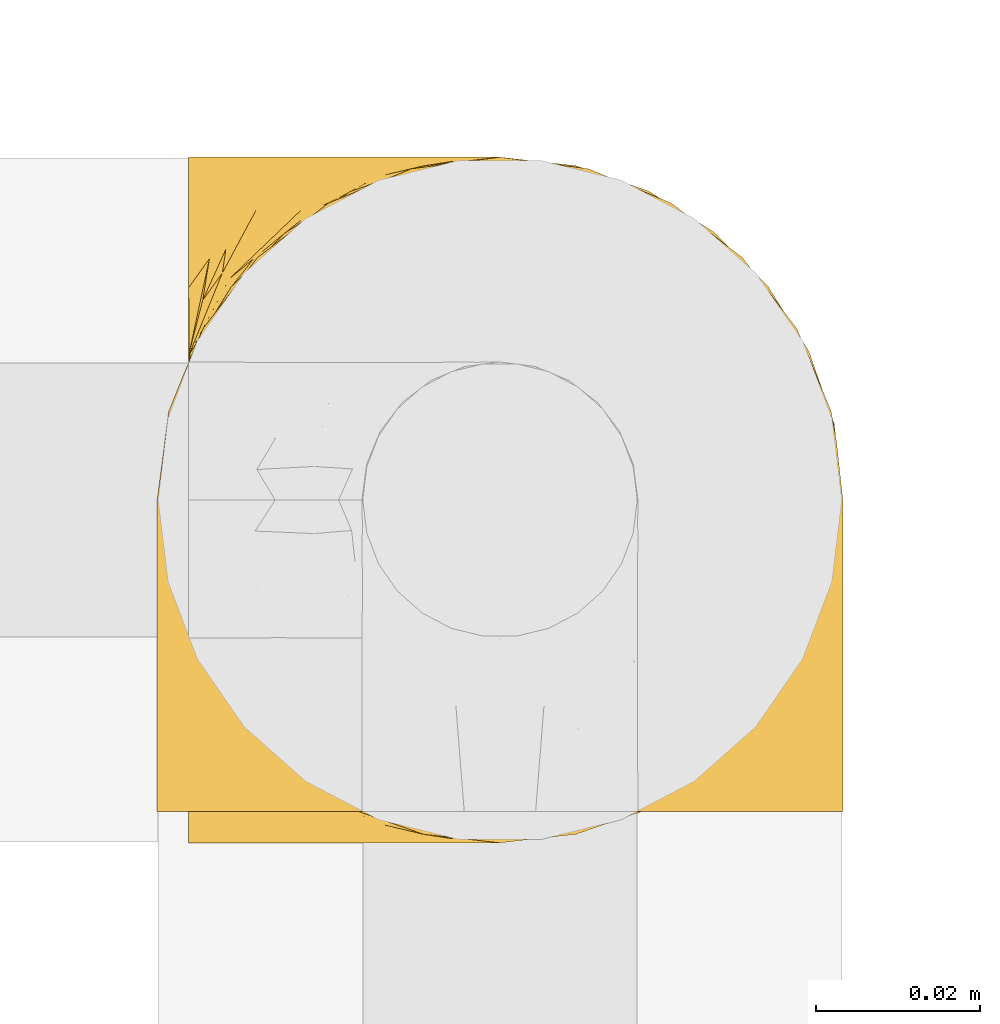
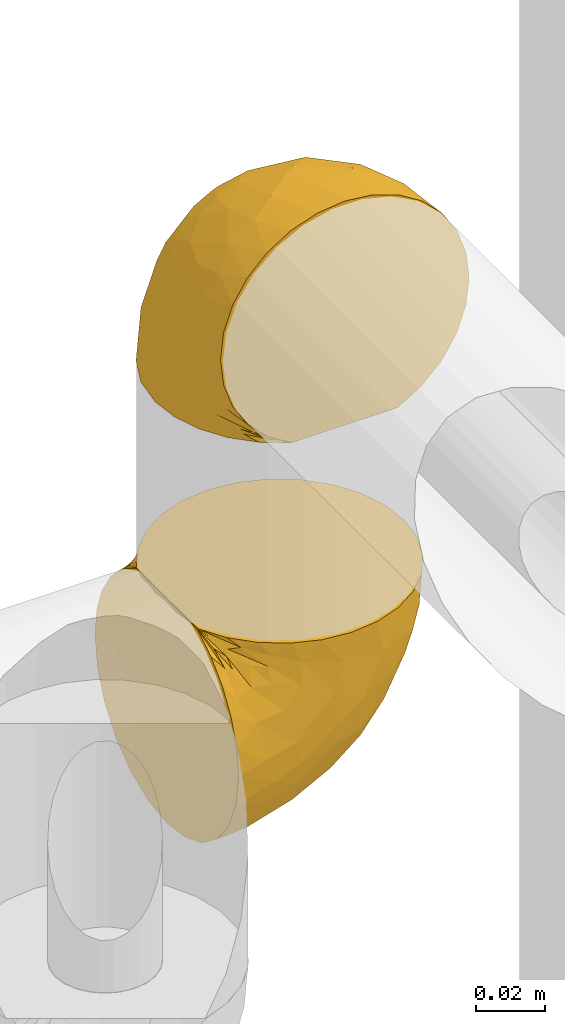
# One storey, part 56 of 827: 2 coverings.
"""IFC2X3 building model written with IfcOpenShell, lengths in millimetres."""

import ifcopenshell
import ifcopenshell.guid

model = None  # the IFC model being written
_history = None  # IfcOwnerHistory: only IFC2X3 demands one
_inside = {}  # id of a spatial element -> (the spatial element, [elements in it])
_under = {}  # id of a project, library or spatial element -> (it, [spatial elements below it])
_declared = {}  # id of a project -> (the project, [libraries it declares])
_typed = {}  # id of a type object -> (the type object, [elements of that type])
_made_of = {}  # id of a material, layer set ... -> (it, [elements and type objects made of it])


def new_model(schema):
    """Start an empty IFC model of exactly this schema.

    Asked for "IFC4X3", IfcOpenShell would pick the latest addendum, in which some entities
    have other attributes; the version numbers below select the first issue.
    IFC2X3 requires an IfcOwnerHistory on every rooted entity: one is made here for all.
    """
    global model, _history
    if schema == "IFC4X3":
        model = ifcopenshell.file(schema_version=(4, 3, 0, 0))
    else:
        model = ifcopenshell.file(schema=schema)
    _inside.clear()
    _under.clear()
    _declared.clear()
    _typed.clear()
    _made_of.clear()
    _history = None
    if model.schema == "IFC2X3":
        org = make("IfcOrganization", Name="unknown")
        user = make(
            "IfcPersonAndOrganization",
            ThePerson=make("IfcPerson", FamilyName="unknown"),
            TheOrganization=org,
        )
        app = make(
            "IfcApplication",
            ApplicationDeveloper=org,
            Version="unknown",
            ApplicationFullName="unknown",
            ApplicationIdentifier="unknown",
        )
        _history = make(
            "IfcOwnerHistory",
            OwningUser=user,
            OwningApplication=app,
            ChangeAction="ADDED",
            CreationDate=0,
        )
    return model


def make(cls, **values):
    """One entity of the class cls with the attributes given. An attribute that is None is left unset."""
    return model.create_entity(
        cls, **{name: value for name, value in values.items() if value is not None}
    )


def entity(cls, *values):
    """Any entity or typed value of the class cls, its attributes in the order of the schema. None: left unset."""
    e = model.create_entity(cls)
    for i, value in enumerate(values):
        if value is not None:
            e[i] = value
    return e


def rooted(cls, **values):
    """An entity with a GlobalId (a new one), such as an element, a storey or a relation."""
    return make(cls, GlobalId=ifcopenshell.guid.new(), OwnerHistory=_history, **values)


def si_unit(unit_type, name, prefix=None):
    """IfcSIUnit, for example si_unit("LENGTHUNIT", "METRE", prefix="MILLI")."""
    return make("IfcSIUnit", UnitType=unit_type, Prefix=prefix, Name=name)


def converted_unit(unit_type, name, factor, base, dimensions=None, offset=None):
    """IfcConversionBasedUnit, such as the inch: factor (a typed value) times the base unit."""
    return make(
        "IfcConversionBasedUnit"
        if offset is None
        else "IfcConversionBasedUnitWithOffset",
        ConversionOffset=offset,
        Dimensions=None
        if dimensions is None
        else entity("IfcDimensionalExponents", *dimensions),
        UnitType=unit_type,
        Name=name,
        ConversionFactor=make(
            "IfcMeasureWithUnit", ValueComponent=factor, UnitComponent=base
        ),
    )


def derived_unit(unit_type, elements):
    """IfcDerivedUnit: a product of units, each with its exponent."""
    return make(
        "IfcDerivedUnit",
        Elements=[
            make("IfcDerivedUnitElement", Unit=unit, Exponent=power)
            for unit, power in elements
        ],
        UnitType=unit_type,
    )


def assignment(units):
    """IfcUnitAssignment: the units of a project."""
    return None if units is None else make("IfcUnitAssignment", Units=units)


def point(xyz):
    """IfcCartesianPoint."""
    return None if xyz is None else make("IfcCartesianPoint", Coordinates=xyz)


def direction(xyz):
    """IfcDirection."""
    return None if xyz is None else make("IfcDirection", DirectionRatios=xyz)


def frame(location, z_axis=None, x_axis=None):
    """IfcAxis2Placement3D, a coordinate frame: its origin and axes. An axis left out is left unset."""
    return make(
        "IfcAxis2Placement3D",
        Location=point(location),
        Axis=direction(z_axis),
        RefDirection=direction(x_axis),
    )


def origin():
    """The frame at (0, 0, 0) with its axes left unset."""
    return frame((0.0, 0.0, 0.0))


def place(relative_to, where):
    """IfcLocalPlacement: puts the frame where relative to a parent placement (None: the world)."""
    return make(
        "IfcLocalPlacement", PlacementRelTo=relative_to, RelativePlacement=where
    )


def context(
    kind, dimensions, precision=None, world=None, true_north=None, identifier=None
):
    """IfcGeometricRepresentationContext, for example the 3D "Model" context."""
    return make(
        "IfcGeometricRepresentationContext",
        ContextIdentifier=identifier,
        ContextType=kind,
        CoordinateSpaceDimension=dimensions,
        Precision=precision,
        WorldCoordinateSystem=world,
        TrueNorth=true_north,
    )


def subcontext(parent, identifier, kind, view, scale=None):
    """IfcGeometricRepresentationSubContext, for example "Body" below "Model"."""
    return make(
        "IfcGeometricRepresentationSubContext",
        ContextIdentifier=identifier,
        ContextType=kind,
        ParentContext=parent,
        TargetScale=scale,
        TargetView=view,
    )


def project(units=None, contexts=None):
    """IfcProject with its units and contexts."""
    return rooted(
        "IfcProject",
        Name="project",
        RepresentationContexts=contexts,
        UnitsInContext=assignment(units),
    )


def spatial(cls, under=None, at=None, **own):
    """A site, building, storey or space (cls), placed at a placement, below another one or the project."""
    s = rooted(cls, ObjectPlacement=at, **own)
    if under is not None:
        _under.setdefault(under.id(), (under, []))[1].append(s)
    return s


def faces_of(points, faces, orient=None, outer=None):
    """IfcFace entities. A face is a list of loops; a loop is a list of indices into points, from 0.

    orient and outer hold one flag for each loop. By default every Orientation is true, the
    first loop of a face is its IfcFaceOuterBound and the others are IfcFaceBound.
    """
    made = []
    for i, loops in enumerate(faces):
        bounds = []
        for j, loop in enumerate(loops):
            is_outer = j == 0 if outer is None else outer[i][j]
            bounds.append(
                make(
                    "IfcFaceOuterBound" if is_outer else "IfcFaceBound",
                    Bound=make("IfcPolyLoop", Polygon=[points[k] for k in loop]),
                    Orientation=True if orient is None else orient[i][j],
                )
            )
        made.append(make("IfcFace", Bounds=bounds))
    return made


def faceted_brep(points, faces, orient=None, outer=None, voids=None):
    """IfcFacetedBrep: a solid bounded by flat faces; with voids (closed shells), ...WithVoids."""
    shared = [point(p) for p in points]
    hull = make("IfcClosedShell", CfsFaces=faces_of(shared, faces, orient, outer))
    if voids is None:
        return make("IfcFacetedBrep", Outer=hull)
    return make(
        "IfcFacetedBrepWithVoids",
        Outer=hull,
        Voids=[
            make(cls, CfsFaces=faces_of(shared, fs, o, b)) for cls, fs, o, b in voids
        ],
    )


def shape(context_of_items, identifier, shape_type, items):
    """IfcShapeRepresentation: the items that make up one representation, for example the "Body"."""
    return make(
        "IfcShapeRepresentation",
        ContextOfItems=context_of_items,
        RepresentationIdentifier=identifier,
        RepresentationType=shape_type,
        Items=items,
    )


def made_of(thing, what):
    """Note that an element or type object is made of a material, layer set ...; save() writes the relation."""
    if what is not None:
        _made_of.setdefault(what.id(), (what, []))[1].append(thing)
    return thing


def element(
    cls,
    number,
    at=None,
    inside=None,
    cuts=None,
    type_object=None,
    material=None,
    context=None,
    identifier="Body",
    shape_type=None,
    held_by="IfcProductDefinitionShape",
    body=None,
    shapes=None,
    **own,
):
    """One element of the class cls, such as IfcWall. Its Tag is "e" and its number.

    at: its placement. inside: the storey or other place that contains it. cuts: it is an
    opening in that element (IfcRelVoidsElement). A single representation is given by context,
    identifier, shape_type and body (its items); several are given by shapes. held_by: the class
    of the entity that holds the representations. save() writes the other relations.
    """
    e = rooted(cls, Tag="e%d" % number, ObjectPlacement=at, **own)
    if body is not None:
        shapes = [shape(context, identifier, shape_type, body)]
    if shapes is not None:
        e.Representation = make(held_by, Representations=shapes)
    if inside is not None:
        _inside.setdefault(inside.id(), (inside, []))[1].append(e)
    if cuts is not None:
        rooted(
            "IfcRelVoidsElement", RelatingBuildingElement=cuts, RelatedOpeningElement=e
        )
    if type_object is not None:
        _typed.setdefault(type_object.id(), (type_object, []))[1].append(e)
    return made_of(e, material)


def aggregate(whole, parts):
    """IfcRelAggregates: a whole, such as a stair, and the parts it consists of."""
    return rooted("IfcRelAggregates", RelatingObject=whole, RelatedObjects=parts)


def save(model, path):
    """Write the relations noted so far, then the file.

    IfcRelAggregates (storeys below a building ...), IfcRelContainedInSpatialStructure (elements
    in a storey), IfcRelDefinesByType, IfcRelAssociatesMaterial and IfcRelDeclares: one each for
    every whole, place, type object, material and project.
    """
    for whole, parts in _under.values():
        aggregate(whole, parts)
    for where, things in _inside.values():
        rooted(
            "IfcRelContainedInSpatialStructure",
            RelatedElements=things,
            RelatingStructure=where,
        )
    for kind, things in _typed.values():
        rooted("IfcRelDefinesByType", RelatedObjects=things, RelatingType=kind)
    for what, things in _made_of.values():
        rooted("IfcRelAssociatesMaterial", RelatedObjects=things, RelatingMaterial=what)
    for by, libraries in _declared.values():
        rooted("IfcRelDeclares", RelatingContext=by, RelatedDefinitions=libraries)
    model.write(path)


model = new_model("IFC2X3")

# Units and contexts
model_context = context("Model", 3, precision=0.01, world=origin(), true_north=direction((6.12303176911189e-17, 1.0)))
body_context = subcontext(model_context, "Body", "Model", "MODEL_VIEW")
ifc_project = project(units=[si_unit("LENGTHUNIT", "METRE", prefix="MILLI"), si_unit("AREAUNIT", "SQUARE_METRE"), si_unit("VOLUMEUNIT", "CUBIC_METRE"), converted_unit("PLANEANGLEUNIT", "DEGREE", entity("IfcRatioMeasure", 0.0174532925199433), si_unit("PLANEANGLEUNIT", "RADIAN"), dimensions=[0, 0, 0, 0, 0, 0, 0]), si_unit("MASSUNIT", "GRAM", prefix="KILO"), derived_unit("MASSDENSITYUNIT", [(si_unit("MASSUNIT", "GRAM", prefix="KILO"), 1), (si_unit("LENGTHUNIT", "METRE"), -3)]), derived_unit("MOMENTOFINERTIAUNIT", [(si_unit("LENGTHUNIT", "METRE"), 4)]), si_unit("TIMEUNIT", "SECOND"), si_unit("FREQUENCYUNIT", "HERTZ"), si_unit("THERMODYNAMICTEMPERATUREUNIT", "DEGREE_CELSIUS"), derived_unit("THERMALTRANSMITTANCEUNIT", [(si_unit("MASSUNIT", "GRAM", prefix="KILO"), 1), (si_unit("THERMODYNAMICTEMPERATUREUNIT", "KELVIN"), -1), (si_unit("TIMEUNIT", "SECOND"), -3)]), derived_unit("VOLUMETRICFLOWRATEUNIT", [(si_unit("LENGTHUNIT", "METRE"), 3), (si_unit("TIMEUNIT", "SECOND"), -1)]), derived_unit("MASSFLOWRATEUNIT", [(si_unit("MASSUNIT", "GRAM", prefix="KILO"), 1), (si_unit("TIMEUNIT", "SECOND"), -1)]), derived_unit("ROTATIONALFREQUENCYUNIT", [(si_unit("TIMEUNIT", "SECOND"), -1)]), si_unit("ELECTRICCURRENTUNIT", "AMPERE"), si_unit("ELECTRICVOLTAGEUNIT", "VOLT"), si_unit("POWERUNIT", "WATT"), si_unit("FORCEUNIT", "NEWTON", prefix="KILO"), si_unit("ILLUMINANCEUNIT", "LUX"), si_unit("LUMINOUSFLUXUNIT", "LUMEN"), si_unit("LUMINOUSINTENSITYUNIT", "CANDELA"), derived_unit("USERDEFINED", [(si_unit("MASSUNIT", "GRAM", prefix="KILO"), -1), (si_unit("LENGTHUNIT", "METRE"), -2), (si_unit("TIMEUNIT", "SECOND"), 3), (si_unit("LUMINOUSFLUXUNIT", "LUMEN"), 1)]), derived_unit("LINEARVELOCITYUNIT", [(si_unit("LENGTHUNIT", "METRE"), 1), (si_unit("TIMEUNIT", "SECOND"), -1)]), si_unit("PRESSUREUNIT", "PASCAL"), derived_unit("USERDEFINED", [(si_unit("LENGTHUNIT", "METRE"), -2), (si_unit("MASSUNIT", "GRAM", prefix="KILO"), 1), (si_unit("TIMEUNIT", "SECOND"), -2)]), derived_unit("LINEARFORCEUNIT", [(si_unit("MASSUNIT", "GRAM", prefix="KILO"), 1), (si_unit("LENGTHUNIT", "METRE"), 1), (si_unit("TIMEUNIT", "SECOND"), -2), (si_unit("LENGTHUNIT", "METRE"), -1)]), derived_unit("PLANARFORCEUNIT", [(si_unit("MASSUNIT", "GRAM", prefix="KILO"), 1), (si_unit("LENGTHUNIT", "METRE"), 1), (si_unit("TIMEUNIT", "SECOND"), -2), (si_unit("LENGTHUNIT", "METRE"), -2)])], contexts=[model_context])

# Site, building, storey
site_placement = place(None, origin())
site = spatial("IfcSite", under=ifc_project, at=site_placement, CompositionType="ELEMENT")
building_placement = place(site_placement, origin())
building = spatial("IfcBuilding", under=site, at=building_placement, CompositionType="ELEMENT")
storey_placement = place(building_placement, frame((0.0, 0.0, 28200.0)))
storey = spatial("IfcBuildingStorey", under=building, at=storey_placement, Name="08", CompositionType="ELEMENT", Elevation=28200.0)

# Coverings
covering_1_placement = place(storey_placement, frame((19227.89, 9699.35, 2806.57)))
element("IfcCovering", 1, at=covering_1_placement, inside=storey, Name=":ADSK_", ObjectType=":ADSK_", PredefinedType="INSULATION", context=body_context, shape_type="Brep", body=[
    faceted_brep([(57.76, 5.74, 81.45), (65.7, 10.73, 81.45), (72.32, 17.36, 81.45), (77.31, 25.29, 81.45), (80.4, 34.14, 81.45), (81.45, 43.45, 81.45), (80.4, 52.76, 81.45), (77.3, 61.61, 81.45), (72.31, 69.54, 81.45), (65.68, 76.17, 81.45), (57.75, 81.15, 81.45), (48.9, 84.25, 81.45), (39.6, 85.3, 81.45), (30.23, 84.23, 81.45), (21.33, 81.1, 81.45), (13.37, 76.06, 81.45), (6.73, 69.36, 81.45), (1.77, 61.36, 81.45), (1.77, 60.44, 81.45), (1.77, 59.52, 81.45), (1.77, 58.72, 81.45), (1.77, 57.4, 81.45), (1.77, 56.08, 81.45), (1.77, 54.76, 81.45), (1.77, 53.44, 81.45), (1.77, 52.12, 81.45), (1.77, 50.8, 81.45), (1.77, 49.47, 81.45), (1.77, 48.15, 81.45), (1.77, 46.83, 81.45), (1.77, 45.51, 81.45), (1.77, 44.19, 81.45), (1.77, 42.87, 81.45), (1.77, 41.55, 81.45), (1.77, 40.23, 81.45), (1.77, 39.31, 81.45), (1.77, 38.39, 81.45), (1.77, 37.48, 81.45), (1.77, 36.56, 81.45), (1.77, 35.64, 81.45), (1.77, 34.72, 81.45), (1.77, 33.8, 81.45), (1.77, 32.88, 81.45), (1.77, 31.96, 81.45), (1.77, 31.05, 81.45), (1.77, 30.13, 81.45), (1.77, 29.21, 81.45), (1.77, 28.29, 81.45), (1.77, 27.37, 81.45), (1.77, 26.45, 81.45), (1.77, 25.53, 81.45), (6.75, 17.52, 81.45), (13.38, 10.82, 81.45), (21.35, 5.78, 81.45), (30.24, 2.65, 81.45), (39.6, 1.6, 81.45), (48.91, 2.65, 81.45), (1.6, 69.37, 76.3), (1.6, 76.06, 69.67), (1.6, 81.1, 61.7), (1.6, 84.23, 52.81), (1.6, 85.3, 43.45), (1.6, 83.87, 32.61), (1.6, 79.69, 22.52), (1.6, 73.04, 13.85), (1.6, 64.37, 7.2), (1.6, 54.28, 3.02), (1.6, 43.45, 1.6), (1.6, 32.61, 3.02), (1.6, 22.52, 7.2), (1.6, 13.85, 13.85), (1.6, 7.2, 22.52), (1.6, 3.02, 32.61), (1.6, 1.6, 43.45), (1.6, 2.66, 52.81), (1.6, 5.79, 61.7), (1.6, 10.83, 69.67), (1.6, 17.52, 76.3), (1.6, 25.53, 81.27), (1.6, 26.45, 81.27), (1.6, 27.77, 81.27), (1.6, 28.89, 81.27), (1.6, 30.01, 81.27), (1.6, 31.13, 81.27), (1.6, 32.25, 81.27), (1.6, 33.37, 81.27), (1.6, 34.49, 81.27), (1.6, 35.61, 81.27), (1.6, 36.73, 81.27), (1.6, 37.85, 81.27), (1.6, 38.97, 81.27), (1.6, 40.09, 81.27), (1.6, 41.21, 81.27), (1.6, 42.33, 81.27), (1.6, 43.45, 81.27), (1.6, 44.77, 81.27), (1.6, 46.09, 81.27), (1.6, 47.41, 81.27), (1.6, 48.73, 81.27), (1.6, 50.05, 81.27), (1.6, 51.37, 81.27), (1.6, 52.69, 81.27), (1.6, 54.01, 81.27), (1.6, 54.93, 81.27), (1.6, 55.85, 81.27), (1.6, 56.76, 81.27), (1.6, 57.68, 81.27), (1.6, 58.6, 81.27), (1.6, 59.52, 81.27), (1.6, 60.44, 81.27), (1.6, 61.36, 81.27), (1.71, 32.81, 81.31), (1.73, 31.73, 81.33), (1.71, 50.71, 81.31), (1.72, 51.76, 81.32), (1.71, 42.89, 81.31), (1.72, 41.81, 81.32), (1.72, 25.53, 81.32), (1.72, 26.91, 81.32), (1.72, 40.71, 81.32), (1.72, 60.15, 81.32), (1.73, 39.53, 81.32), (1.72, 57.22, 81.32), (1.7, 58.17, 81.3), (1.72, 47.12, 81.32), (1.73, 33.93, 81.33), (1.72, 35.05, 81.31), (1.73, 46.09, 81.33), (1.73, 45.02, 81.32), (1.72, 43.95, 81.32), (1.72, 59.12, 81.32), (1.72, 38.49, 81.31), (1.72, 49.68, 81.32), (1.71, 53.35, 81.31), (1.72, 54.4, 81.32), (1.72, 56.2, 81.32), (1.72, 36.2, 81.32), (1.73, 37.29, 81.33), (1.72, 30.57, 81.32), (1.72, 29.45, 81.31), (1.73, 28.01, 81.33), (1.72, 61.36, 81.32), (1.74, 25.53, 81.36), (1.74, 61.36, 81.36), (1.65, 25.53, 81.29), (1.65, 61.36, 81.29), (1.68, 61.36, 81.3), (1.68, 25.53, 81.3), (1.75, 61.36, 81.4), (1.75, 25.53, 81.4), (1.74, 55.3, 81.35), (1.71, 48.18, 81.31), (8.98, 82.92, 58.5), (37.05, 85.3, 71.95), (24.69, 82.92, 74.57), (15.28, 78.8, 73.93), (16.86, 78.8, 78.18), (6.58, 70.46, 78.04), (5.71, 71.16, 76.23), (11.1, 85.3, 45.99), (10.79, 76.1, 74.01), (4.13, 72.9, 73.57), (6.62, 78.81, 66.66), (9.52, 72.89, 79.09), (6.14, 74.06, 73.14), (17.79, 83.71, 60.34), (20.6, 85.3, 48.54), (23.66, 83.61, 67.22), (34.51, 85.3, 62.45), (15.33, 80.61, 68.67), (27.55, 85.3, 55.49), (3.31, 67.83, 77.84), (9.81, 78.81, 68.16), (37.68, 85.3, 74.31), (67.23, 54.78, 38.78), (76.64, 57.27, 62.1), (75.37, 43.45, 50.89), (14.68, 84.37, 36.55), (10.98, 82.11, 28.25), (22.27, 82.11, 31.54), (56.79, 78.88, 57.26), (60.76, 78.88, 69.99), (67.04, 73.04, 64.58), (53.42, 51.18, 21.64), (58.19, 57.42, 28.57), (68.85, 65.72, 51.97), (24.58, 51.16, 5.72), (21.54, 59.46, 7.42), (78.4, 43.45, 66.14), (14.11, 68.92, 11.35), (18.02, 76.65, 20.13), (36.12, 84.47, 50.64), (23.72, 84.39, 40.37), (44.5, 83.48, 55.38), (51.77, 82.95, 68.51), (73.69, 65.72, 67.48), (45.89, 78.97, 40.78), (34.34, 77.16, 27.86), (35.97, 82.64, 41.53), (56.55, 75.14, 46.11), (60.04, 68.58, 40.32), (63.64, 61.95, 38.36), (34.98, 58.11, 11.84), (29.1, 68.92, 15.77), (40.58, 51.07, 12.56), (32.15, 43.45, 7.67), (58.06, 43.45, 24.98), (66.71, 43.45, 37.93), (47.26, 58.51, 19.39), (16.9, 43.45, 4.64), (52.09, 65.68, 28.09), (41.21, 70.41, 23.73), (49.76, 73.04, 34.03), (45.11, 43.45, 16.33), (44.5, 3.41, 55.37), (35.97, 4.26, 41.52), (45.9, 7.93, 40.79), (24.58, 35.73, 5.72), (21.54, 27.43, 7.42), (34.99, 28.78, 11.85), (29.11, 17.97, 15.77), (14.12, 17.97, 11.35), (18.02, 10.24, 20.13), (40.58, 35.82, 12.56), (53.41, 35.72, 21.64), (47.27, 28.38, 19.4), (56.8, 8.01, 57.26), (60.77, 8.01, 69.99), (51.79, 3.95, 68.51), (52.11, 21.22, 28.11), (41.23, 16.49, 23.73), (11.1, 1.6, 45.99), (14.68, 2.52, 36.55), (23.72, 2.5, 40.37), (37.68, 1.6, 74.31), (22.27, 4.78, 31.54), (10.98, 4.78, 28.25), (67.25, 32.11, 38.8), (76.65, 29.63, 62.11), (68.86, 21.19, 51.98), (73.7, 21.19, 67.49), (67.06, 13.86, 64.58), (20.6, 1.6, 48.54), (49.79, 13.86, 34.04), (60.06, 18.32, 40.33), (56.57, 11.77, 46.12), (34.51, 1.6, 62.45), (34.36, 9.74, 27.86), (37.05, 1.6, 71.95), (58.2, 29.48, 28.58), (36.11, 2.42, 50.64), (27.55, 1.6, 55.49), (63.65, 24.95, 38.36), (8.98, 3.97, 58.5), (23.67, 3.27, 67.22), (24.71, 3.97, 74.57), (15.29, 8.08, 73.92), (4.13, 13.99, 73.57), (6.14, 12.83, 73.14), (4.96, 8.08, 66.19), (9.81, 8.08, 68.16), (3.31, 19.06, 77.84), (5.71, 15.74, 76.23), (9.53, 13.98, 79.08), (6.59, 16.42, 78.04), (16.63, 8.08, 77.18), (15.35, 6.27, 68.66), (10.8, 10.78, 74.0), (17.79, 3.18, 60.34)], [[[0, 1, 2, 3, 4, 5, 6, 7, 8, 9, 10, 11, 12, 13, 14, 15, 16, 17, 18, 19, 20, 21, 22, 23, 24, 25, 26, 27, 28, 29, 30, 31, 32, 33, 34, 35, 36, 37, 38, 39, 40, 41, 42, 43, 44, 45, 46, 47, 48, 49, 50, 51, 52, 53, 54, 55, 56]], [[57, 58, 59, 60, 61, 62, 63, 64, 65, 66, 67, 68, 69, 70, 71, 72, 73, 74, 75, 76, 77, 78, 79, 80, 81, 82, 83, 84, 85, 86, 87, 88, 89, 90, 91, 92, 93, 94, 95, 96, 97, 98, 99, 100, 101, 102, 103, 104, 105, 106, 107, 108, 109, 110]], [[111, 84, 112]], [[113, 26, 114]], [[114, 101, 100]], [[115, 93, 116]], [[79, 117, 118]], [[33, 116, 119]], [[117, 49, 118]], [[19, 18, 120]], [[119, 121, 34]], [[122, 21, 123]], [[97, 96, 124]], [[86, 125, 126]], [[116, 92, 119]], [[127, 96, 128]], [[32, 129, 115]], [[19, 120, 130]], [[121, 90, 131]], [[94, 115, 129]], [[115, 116, 32]], [[118, 49, 48]], [[113, 99, 132]], [[133, 114, 25]], [[24, 134, 133]], [[135, 22, 122]], [[136, 137, 88]], [[84, 83, 112]], [[138, 82, 139]], [[130, 20, 19]], [[118, 48, 140]], [[81, 140, 139]], [[123, 21, 20]], [[141, 120, 18]], [[139, 82, 81]], [[130, 107, 123]], [[49, 117, 142]], [[18, 143, 141]], [[79, 78, 144]], [[109, 145, 110]], [[102, 133, 134]], [[105, 135, 122]], [[109, 141, 146]], [[79, 147, 117]], [[118, 80, 79]], [[80, 118, 140]], [[18, 17, 148]], [[49, 149, 50]], [[120, 109, 108]], [[47, 46, 140, 48]], [[81, 80, 140]], [[44, 112, 138]], [[93, 115, 94]], [[46, 139, 140]], [[46, 45, 139]], [[139, 45, 138]], [[138, 112, 83]], [[85, 84, 111]], [[112, 43, 111]], [[83, 82, 138]], [[106, 122, 123]], [[105, 122, 106]], [[21, 122, 22]], [[124, 29, 28]], [[33, 32, 116]], [[128, 129, 31]], [[32, 31, 129]], [[34, 33, 119]], [[116, 93, 92]], [[129, 95, 94]], [[95, 129, 128]], [[41, 40, 125, 42]], [[119, 91, 121]], [[36, 35, 131, 37]], [[137, 131, 89]], [[121, 131, 35]], [[90, 121, 91]], [[119, 92, 91]], [[136, 126, 39]], [[125, 86, 85]], [[42, 125, 111]], [[85, 111, 125]], [[150, 23, 22]], [[130, 108, 107]], [[130, 123, 20]], [[107, 106, 123]], [[137, 37, 131]], [[136, 38, 137]], [[89, 88, 137]], [[131, 90, 89]], [[124, 151, 97]], [[40, 39, 126]], [[87, 126, 136]], [[86, 126, 87]], [[136, 88, 87]], [[40, 126, 125]], [[39, 38, 136]], [[95, 128, 96]], [[30, 128, 31]], [[29, 124, 127]], [[127, 128, 30]], [[151, 124, 28]], [[127, 30, 29]], [[127, 124, 96]], [[151, 98, 97]], [[45, 44, 138]], [[26, 113, 132]], [[113, 100, 99]], [[132, 151, 27]], [[27, 26, 132]], [[26, 25, 114]], [[100, 113, 114]], [[101, 133, 102]], [[133, 101, 114]], [[28, 27, 151]], [[132, 99, 98]], [[23, 134, 24]], [[25, 24, 133]], [[134, 23, 150]], [[135, 104, 150]], [[150, 104, 103]], [[103, 102, 134]], [[130, 120, 108]], [[109, 120, 141]], [[42, 111, 43]], [[112, 44, 43]], [[104, 135, 105]], [[134, 150, 103]], [[135, 150, 22]], [[35, 34, 121]], [[137, 38, 37]], [[98, 151, 132]], [[59, 152, 60]], [[13, 153, 154]], [[155, 156, 154]], [[157, 158, 141]], [[159, 60, 152]], [[160, 157, 155]], [[161, 162, 58]], [[58, 162, 59]], [[148, 16, 163]], [[58, 57, 161]], [[162, 161, 164]], [[157, 163, 155]], [[163, 16, 15]], [[57, 145, 161]], [[152, 165, 166]], [[157, 148, 163]], [[159, 61, 60]], [[156, 14, 154]], [[163, 156, 155]], [[155, 154, 167]], [[167, 154, 168]], [[155, 169, 160]], [[57, 110, 145]], [[148, 17, 16]], [[156, 15, 14]], [[170, 165, 167]], [[158, 164, 171]], [[14, 13, 154]], [[157, 143, 148]], [[172, 164, 158]], [[172, 160, 169]], [[170, 166, 165]], [[167, 165, 169]], [[167, 168, 170]], [[152, 172, 165]], [[169, 155, 167]], [[165, 172, 169]], [[160, 172, 158]], [[171, 145, 146]], [[146, 141, 158]], [[158, 157, 160]], [[152, 166, 159]], [[172, 152, 162]], [[59, 162, 152]], [[13, 12, 173, 153]], [[153, 168, 154]], [[15, 156, 163]], [[157, 141, 143]], [[162, 164, 172]], [[171, 164, 161]], [[145, 171, 161]], [[158, 171, 146]], [[174, 175, 176]], [[61, 159, 177]], [[178, 63, 62]], [[177, 179, 178]], [[180, 181, 182]], [[174, 183, 184]], [[173, 12, 11]], [[185, 175, 174]], [[186, 66, 187]], [[175, 6, 188]], [[189, 65, 64]], [[190, 64, 63]], [[65, 187, 66]], [[65, 189, 187]], [[190, 63, 178]], [[170, 191, 192]], [[193, 168, 194]], [[173, 11, 194]], [[8, 7, 195]], [[182, 9, 8]], [[194, 168, 153, 173]], [[194, 11, 10]], [[181, 194, 10]], [[196, 197, 198]], [[194, 180, 193]], [[199, 185, 200]], [[199, 182, 185]], [[184, 201, 174]], [[187, 202, 186]], [[175, 7, 6]], [[176, 175, 188]], [[185, 195, 175]], [[203, 190, 197]], [[195, 182, 8]], [[204, 205, 186]], [[9, 181, 10]], [[197, 190, 179]], [[206, 174, 176, 207]], [[159, 192, 177]], [[189, 190, 203]], [[203, 208, 202]], [[66, 186, 209]], [[210, 211, 212]], [[186, 202, 204]], [[193, 180, 196]], [[193, 198, 191]], [[6, 5, 188]], [[175, 195, 7]], [[182, 195, 185]], [[182, 181, 9]], [[194, 181, 180]], [[198, 197, 179]], [[197, 212, 211]], [[192, 179, 177]], [[180, 199, 196]], [[209, 186, 205]], [[209, 67, 66]], [[204, 202, 208]], [[183, 204, 208]], [[183, 213, 204]], [[184, 183, 208]], [[206, 183, 174]], [[208, 210, 184]], [[200, 201, 210]], [[211, 208, 203]], [[200, 210, 212]], [[199, 200, 212]], [[185, 174, 201]], [[196, 199, 212]], [[182, 199, 180]], [[197, 196, 212]], [[193, 196, 198]], [[210, 201, 184]], [[185, 201, 200]], [[208, 211, 210]], [[197, 211, 203]], [[213, 183, 206]], [[213, 205, 204]], [[193, 191, 168]], [[203, 202, 187]], [[190, 189, 64]], [[187, 189, 203]], [[62, 61, 177]], [[190, 178, 179]], [[62, 177, 178]], [[192, 159, 166]], [[170, 192, 166]], [[198, 179, 192]], [[192, 191, 198]], [[168, 191, 170]], [[214, 215, 216]], [[205, 217, 209]], [[218, 219, 220]], [[218, 220, 221]], [[222, 71, 70]], [[223, 224, 225]], [[226, 227, 228]], [[229, 230, 225]], [[231, 232, 233]], [[56, 234, 228]], [[222, 235, 236]], [[56, 55, 234]], [[72, 236, 232]], [[236, 72, 71]], [[0, 56, 228]], [[69, 68, 218]], [[237, 176, 238]], [[221, 222, 70]], [[239, 240, 241]], [[1, 241, 2]], [[69, 221, 70]], [[238, 3, 240]], [[238, 188, 4]], [[1, 0, 227]], [[241, 240, 2]], [[233, 242, 231]], [[243, 244, 245]], [[226, 228, 214]], [[228, 246, 214]], [[3, 238, 4]], [[222, 247, 235]], [[227, 241, 1]], [[237, 238, 239]], [[241, 226, 245]], [[244, 243, 229]], [[3, 2, 240]], [[237, 206, 207, 176]], [[228, 234, 248, 246]], [[72, 232, 73]], [[220, 230, 247]], [[68, 209, 217]], [[223, 225, 219]], [[223, 219, 217]], [[225, 224, 249]], [[250, 246, 251]], [[215, 235, 247]], [[188, 238, 176]], [[188, 5, 4]], [[238, 240, 239]], [[228, 227, 0]], [[241, 227, 226]], [[220, 247, 222]], [[245, 216, 243]], [[216, 247, 243]], [[214, 250, 215]], [[68, 67, 209]], [[217, 205, 223]], [[68, 217, 218]], [[224, 213, 206]], [[213, 224, 223]], [[246, 250, 214]], [[249, 224, 237]], [[252, 239, 244]], [[229, 225, 249]], [[249, 237, 252]], [[230, 229, 243]], [[252, 229, 249]], [[239, 241, 245]], [[245, 244, 239]], [[226, 214, 216]], [[216, 245, 226]], [[247, 216, 215]], [[239, 252, 237]], [[229, 252, 244]], [[247, 230, 243]], [[225, 230, 220]], [[223, 205, 213]], [[220, 219, 225]], [[233, 251, 242]], [[217, 219, 218]], [[218, 221, 69]], [[222, 221, 220]], [[222, 236, 71]], [[232, 236, 235]], [[232, 235, 233]], [[232, 231, 73]], [[235, 215, 233]], [[233, 215, 250]], [[206, 237, 224]], [[233, 250, 251]], [[74, 231, 253]], [[254, 255, 256]], [[144, 77, 257]], [[258, 259, 260]], [[261, 257, 258]], [[261, 262, 147]], [[75, 74, 253]], [[51, 149, 263]], [[264, 149, 142]], [[257, 77, 76]], [[253, 259, 75]], [[254, 246, 255]], [[255, 248, 54]], [[259, 257, 76]], [[53, 52, 265]], [[256, 266, 254]], [[255, 265, 256]], [[256, 265, 263]], [[75, 259, 76]], [[266, 256, 267]], [[256, 263, 264]], [[51, 50, 149]], [[54, 248, 234, 55]], [[51, 263, 52]], [[254, 268, 251]], [[255, 54, 53]], [[267, 260, 266]], [[144, 78, 77]], [[264, 117, 262]], [[144, 257, 261]], [[258, 260, 262]], [[268, 254, 266]], [[242, 268, 253]], [[251, 268, 242]], [[251, 246, 254]], [[253, 268, 260]], [[256, 264, 267]], [[260, 268, 266]], [[262, 117, 147]], [[264, 262, 267]], [[260, 267, 262]], [[231, 74, 73]], [[231, 242, 253]], [[260, 259, 253]], [[255, 246, 248]], [[53, 265, 255]], [[52, 263, 265]], [[149, 264, 263]], [[142, 117, 264]], [[259, 258, 257]], [[262, 261, 258]], [[144, 261, 147]], [[49, 142, 149]], [[18, 148, 143]], [[79, 144, 147]], [[109, 146, 145]]]),
])
covering_2_placement = place(storey_placement, frame((19224.04, 9703.2, 2957.63)))
element("IfcCovering", 2, at=covering_2_placement, inside=storey, Name=":ADSK_", ObjectType=":ADSK_", PredefinedType="INSULATION", context=body_context, shape_type="Brep", body=[
    faceted_brep([(81.15, 1.6, 57.76), (76.16, 1.6, 65.69), (69.53, 1.6, 72.32), (61.6, 1.6, 77.3), (52.75, 1.6, 80.4), (43.45, 1.6, 81.45), (34.13, 1.6, 80.39), (25.28, 1.6, 77.3), (17.35, 1.6, 72.31), (10.72, 1.6, 65.68), (5.74, 1.6, 57.75), (2.64, 1.6, 48.9), (1.6, 1.6, 39.6), (2.66, 1.6, 30.22), (5.79, 1.6, 21.33), (10.83, 1.6, 13.37), (17.53, 1.6, 6.73), (25.53, 1.6, 1.77), (26.45, 1.6, 1.77), (27.37, 1.6, 1.77), (28.17, 1.6, 1.77), (29.49, 1.6, 1.77), (30.81, 1.6, 1.77), (32.13, 1.6, 1.77), (33.45, 1.6, 1.77), (34.78, 1.6, 1.77), (36.1, 1.6, 1.77), (37.42, 1.6, 1.77), (38.74, 1.6, 1.77), (40.06, 1.6, 1.77), (41.38, 1.6, 1.77), (42.7, 1.6, 1.77), (44.02, 1.6, 1.77), (45.34, 1.6, 1.77), (46.66, 1.6, 1.77), (47.58, 1.6, 1.77), (48.5, 1.6, 1.77), (49.41, 1.6, 1.77), (50.33, 1.6, 1.77), (51.25, 1.6, 1.77), (52.17, 1.6, 1.77), (53.09, 1.6, 1.77), (54.01, 1.6, 1.77), (54.93, 1.6, 1.77), (55.85, 1.6, 1.77), (56.76, 1.6, 1.77), (57.68, 1.6, 1.77), (58.6, 1.6, 1.77), (59.52, 1.6, 1.77), (60.44, 1.6, 1.77), (61.36, 1.6, 1.77), (69.37, 1.6, 6.74), (76.07, 1.6, 13.38), (81.11, 1.6, 21.35), (84.24, 1.6, 30.24), (85.3, 1.6, 39.6), (84.24, 1.6, 48.91), (17.52, 6.74, 1.6), (10.83, 13.37, 1.6), (5.79, 21.34, 1.6), (2.66, 30.23, 1.6), (1.6, 39.6, 1.6), (3.02, 50.43, 1.6), (7.2, 60.52, 1.6), (13.85, 69.19, 1.6), (22.52, 75.84, 1.6), (32.61, 80.02, 1.6), (43.45, 81.45, 1.6), (54.28, 80.02, 1.6), (64.37, 75.84, 1.6), (73.04, 69.19, 1.6), (79.69, 60.52, 1.6), (83.87, 50.43, 1.6), (85.3, 39.6, 1.6), (84.23, 30.23, 1.6), (81.1, 21.34, 1.6), (76.06, 13.37, 1.6), (69.37, 6.74, 1.6), (61.36, 1.77, 1.6), (60.44, 1.77, 1.6), (59.12, 1.77, 1.6), (58.0, 1.77, 1.6), (56.88, 1.77, 1.6), (55.76, 1.77, 1.6), (54.64, 1.77, 1.6), (53.52, 1.77, 1.6), (52.4, 1.77, 1.6), (51.28, 1.77, 1.6), (50.16, 1.77, 1.6), (49.04, 1.77, 1.6), (47.92, 1.77, 1.6), (46.8, 1.77, 1.6), (45.68, 1.77, 1.6), (44.56, 1.77, 1.6), (43.45, 1.77, 1.6), (42.12, 1.77, 1.6), (40.8, 1.77, 1.6), (39.48, 1.77, 1.6), (38.16, 1.77, 1.6), (36.84, 1.77, 1.6), (35.52, 1.77, 1.6), (34.2, 1.77, 1.6), (32.88, 1.77, 1.6), (31.96, 1.77, 1.6), (31.05, 1.77, 1.6), (30.13, 1.77, 1.6), (29.21, 1.77, 1.6), (28.29, 1.77, 1.6), (27.37, 1.77, 1.6), (26.45, 1.77, 1.6), (25.53, 1.77, 1.6), (54.08, 1.73, 1.71), (55.16, 1.72, 1.73), (36.18, 1.73, 1.71), (35.13, 1.72, 1.72), (44.01, 1.73, 1.71), (45.08, 1.73, 1.72), (61.36, 1.72, 1.72), (59.98, 1.72, 1.72), (46.18, 1.72, 1.72), (26.74, 1.72, 1.72), (47.36, 1.72, 1.72), (29.67, 1.73, 1.72), (28.72, 1.74, 1.7), (39.77, 1.72, 1.72), (52.96, 1.71, 1.73), (51.84, 1.73, 1.72), (40.8, 1.71, 1.73), (41.87, 1.72, 1.73), (42.94, 1.73, 1.72), (27.77, 1.72, 1.72), (48.4, 1.73, 1.71), (37.21, 1.72, 1.72), (33.54, 1.73, 1.71), (32.49, 1.72, 1.72), (30.69, 1.72, 1.72), (50.69, 1.72, 1.72), (49.6, 1.71, 1.73), (56.32, 1.72, 1.72), (57.44, 1.73, 1.71), (58.88, 1.71, 1.73), (25.53, 1.72, 1.72), (61.36, 1.68, 1.74), (61.36, 1.64, 1.75), (25.53, 1.64, 1.75), (25.53, 1.68, 1.74), (61.36, 1.75, 1.64), (61.36, 1.74, 1.68), (25.53, 1.74, 1.68), (25.53, 1.75, 1.64), (31.59, 1.7, 1.74), (38.71, 1.73, 1.71), (3.97, 24.54, 8.98), (1.6, 11.1, 37.05), (3.97, 8.47, 24.69), (8.09, 9.11, 15.28), (8.09, 4.86, 16.86), (16.43, 5.0, 6.58), (15.73, 6.81, 5.71), (1.6, 37.05, 11.1), (10.79, 9.03, 10.79), (13.99, 9.47, 4.13), (8.08, 16.39, 6.62), (14.0, 3.95, 9.52), (12.83, 9.9, 6.14), (3.18, 22.7, 17.79), (1.6, 34.5, 20.59), (1.6, 37.68, 8.73), (3.28, 15.82, 23.66), (1.6, 20.6, 34.5), (6.28, 14.37, 15.32), (1.6, 27.55, 27.55), (19.06, 5.2, 3.31), (8.08, 14.88, 9.81), (1.6, 8.74, 37.68), (32.11, 44.27, 67.23), (29.62, 20.94, 76.64), (43.45, 32.15, 75.37), (2.45, 46.13, 14.58), (2.5, 42.67, 23.71), (9.73, 55.18, 34.34), (17.97, 67.27, 29.1), (10.24, 62.91, 18.02), (4.78, 51.5, 22.27), (4.78, 54.79, 10.97), (8.01, 25.79, 56.79), (8.01, 13.06, 60.75), (13.85, 18.47, 67.04), (2.42, 32.4, 36.11), (21.17, 31.08, 68.85), (35.73, 77.32, 24.58), (27.43, 75.62, 21.53), (43.45, 16.91, 78.4), (17.97, 71.69, 14.11), (35.71, 61.39, 53.42), (29.47, 54.47, 58.19), (3.41, 27.66, 44.49), (3.94, 14.53, 51.77), (21.17, 15.56, 73.69), (7.93, 42.26, 45.89), (4.25, 41.52, 35.97), (11.75, 36.94, 56.55), (18.31, 42.72, 60.03), (24.94, 44.68, 63.64), (28.78, 71.2, 34.98), (35.82, 70.48, 40.58), (43.45, 75.37, 32.15), (28.38, 63.65, 47.25), (43.45, 58.06, 58.06), (43.45, 45.11, 66.71), (43.45, 78.4, 16.9), (21.21, 54.95, 52.08), (16.48, 59.31, 41.21), (13.85, 49.01, 49.76), (43.45, 66.71, 45.1), (82.11, 53.75, 15.65), (51.41, 77.27, 24.57), (57.45, 61.6, 50.54), (54.78, 44.25, 67.24), (73.03, 18.46, 67.05), (65.7, 15.55, 73.7), (76.65, 60.14, 26.13), (68.92, 70.5, 19.54), (68.01, 63.0, 38.96), (78.88, 25.78, 56.8), (78.88, 13.05, 60.77), (82.94, 14.53, 51.78), (64.44, 48.5, 59.09), (84.49, 44.23, 19.25), (85.3, 34.5, 20.59), (85.3, 37.05, 11.1), (85.3, 8.74, 37.68), (57.84, 77.68, 15.21), (76.65, 64.08, 12.76), (51.19, 70.25, 40.93), (57.26, 20.94, 76.65), (78.14, 49.9, 39.49), (82.35, 49.6, 25.01), (65.7, 31.07, 68.86), (84.61, 39.62, 26.7), (84.36, 34.42, 34.95), (85.3, 20.6, 34.5), (85.3, 27.55, 27.55), (73.03, 33.36, 61.26), (83.48, 27.68, 44.5), (85.3, 11.1, 37.05), (84.54, 46.67, 10.25), (73.03, 49.0, 49.78), (79.54, 38.94, 47.51), (59.46, 73.05, 29.38), (73.5, 56.63, 40.01), (82.57, 43.85, 33.36), (82.92, 24.54, 8.98), (83.62, 15.82, 23.67), (82.92, 8.47, 24.71), (78.81, 9.12, 15.29), (72.9, 9.47, 4.13), (74.07, 9.91, 6.14), (78.81, 16.85, 4.96), (78.81, 14.88, 9.81), (67.83, 5.2, 3.31), (71.15, 6.81, 5.7), (72.91, 3.96, 9.53), (70.47, 5.0, 6.59), (78.81, 5.86, 16.63), (80.62, 14.38, 15.34), (76.11, 9.04, 10.8), (83.71, 22.7, 17.79)], [[[0, 1, 2, 3, 4, 5, 6, 7, 8, 9, 10, 11, 12, 13, 14, 15, 16, 17, 18, 19, 20, 21, 22, 23, 24, 25, 26, 27, 28, 29, 30, 31, 32, 33, 34, 35, 36, 37, 38, 39, 40, 41, 42, 43, 44, 45, 46, 47, 48, 49, 50, 51, 52, 53, 54, 55, 56]], [[57, 58, 59, 60, 61, 62, 63, 64, 65, 66, 67, 68, 69, 70, 71, 72, 73, 74, 75, 76, 77, 78, 79, 80, 81, 82, 83, 84, 85, 86, 87, 88, 89, 90, 91, 92, 93, 94, 95, 96, 97, 98, 99, 100, 101, 102, 103, 104, 105, 106, 107, 108, 109, 110]], [[111, 84, 112]], [[113, 26, 114]], [[114, 101, 100]], [[115, 93, 116]], [[79, 117, 118]], [[33, 116, 119]], [[117, 49, 118]], [[19, 18, 120]], [[119, 121, 34]], [[122, 21, 123]], [[97, 96, 124]], [[86, 125, 126]], [[116, 92, 119]], [[127, 96, 128]], [[32, 129, 115]], [[19, 120, 130]], [[121, 90, 131]], [[94, 115, 129]], [[115, 116, 32]], [[118, 49, 48]], [[113, 99, 132]], [[133, 114, 25]], [[24, 134, 133]], [[135, 22, 122]], [[136, 137, 88]], [[84, 83, 112]], [[138, 82, 139]], [[130, 20, 19]], [[118, 48, 140]], [[81, 140, 139]], [[123, 21, 20]], [[141, 120, 18]], [[139, 82, 81]], [[130, 107, 123]], [[49, 117, 142, 143, 50]], [[18, 17, 144, 145, 141]], [[79, 78, 146, 147, 117]], [[109, 141, 148, 149, 110]], [[102, 133, 134]], [[105, 135, 122]], [[118, 80, 79]], [[80, 118, 140]], [[120, 109, 108]], [[47, 46, 140, 48]], [[81, 80, 140]], [[44, 112, 138]], [[93, 115, 94]], [[46, 139, 140]], [[46, 45, 139]], [[139, 45, 138]], [[138, 112, 83]], [[85, 84, 111]], [[112, 43, 111]], [[83, 82, 138]], [[106, 122, 123]], [[105, 122, 106]], [[21, 122, 22]], [[124, 29, 28]], [[33, 32, 116]], [[128, 129, 31]], [[32, 31, 129]], [[34, 33, 119]], [[116, 93, 92]], [[129, 95, 94]], [[95, 129, 128]], [[41, 40, 125, 42]], [[119, 91, 121]], [[36, 35, 131, 37]], [[137, 131, 89]], [[121, 131, 35]], [[90, 121, 91]], [[119, 92, 91]], [[136, 126, 39]], [[125, 86, 85]], [[42, 125, 111]], [[85, 111, 125]], [[150, 23, 22]], [[130, 108, 107]], [[130, 123, 20]], [[107, 106, 123]], [[137, 37, 131]], [[136, 38, 137]], [[89, 88, 137]], [[131, 90, 89]], [[124, 151, 97]], [[40, 39, 126]], [[87, 126, 136]], [[86, 126, 87]], [[136, 88, 87]], [[40, 126, 125]], [[39, 38, 136]], [[95, 128, 96]], [[30, 128, 31]], [[29, 124, 127]], [[127, 128, 30]], [[151, 124, 28]], [[127, 30, 29]], [[127, 124, 96]], [[151, 98, 97]], [[45, 44, 138]], [[26, 113, 132]], [[113, 100, 99]], [[132, 151, 27]], [[27, 26, 132]], [[26, 25, 114]], [[100, 113, 114]], [[101, 133, 102]], [[133, 101, 114]], [[28, 27, 151]], [[132, 99, 98]], [[23, 134, 24]], [[25, 24, 133]], [[134, 23, 150]], [[135, 104, 150]], [[150, 104, 103]], [[103, 102, 134]], [[130, 120, 108]], [[109, 120, 141]], [[42, 111, 43]], [[112, 44, 43]], [[104, 135, 105]], [[134, 150, 103]], [[135, 150, 22]], [[35, 34, 121]], [[137, 38, 37]], [[98, 151, 132]], [[59, 152, 60]], [[13, 153, 154]], [[155, 156, 154]], [[157, 158, 141]], [[159, 60, 152]], [[160, 157, 155]], [[161, 162, 58]], [[58, 162, 59]], [[144, 16, 163]], [[58, 57, 161]], [[162, 161, 164]], [[157, 163, 155]], [[163, 16, 15]], [[57, 149, 161]], [[152, 165, 166]], [[157, 144, 163]], [[60, 159, 167, 61]], [[156, 14, 154]], [[163, 156, 155]], [[155, 154, 168]], [[168, 154, 169]], [[155, 170, 160]], [[57, 110, 149]], [[144, 17, 16]], [[156, 15, 14]], [[171, 165, 168]], [[158, 164, 172]], [[14, 13, 154]], [[157, 141, 145, 144]], [[173, 164, 158]], [[173, 160, 170]], [[171, 166, 165]], [[168, 165, 170]], [[168, 169, 171]], [[152, 173, 165]], [[170, 155, 168]], [[165, 173, 170]], [[160, 173, 158]], [[172, 149, 148]], [[148, 141, 158]], [[158, 157, 160]], [[152, 166, 159]], [[173, 152, 162]], [[59, 162, 152]], [[13, 12, 174, 153]], [[153, 169, 154]], [[15, 156, 163]], [[162, 164, 173]], [[172, 164, 161]], [[149, 172, 161]], [[158, 172, 148]], [[175, 176, 177]], [[178, 166, 179]], [[180, 181, 182]], [[183, 184, 178]], [[185, 186, 187]], [[171, 188, 179]], [[174, 12, 11]], [[189, 176, 175]], [[190, 66, 191]], [[176, 6, 192]], [[193, 65, 64]], [[63, 184, 182]], [[63, 182, 64]], [[65, 193, 191]], [[184, 63, 62]], [[175, 194, 195]], [[196, 169, 197]], [[174, 11, 197]], [[8, 7, 198]], [[187, 9, 8]], [[197, 169, 153, 174]], [[197, 11, 10]], [[186, 197, 10]], [[199, 180, 200]], [[197, 185, 196]], [[201, 189, 202]], [[201, 187, 189]], [[195, 203, 175]], [[191, 204, 190]], [[176, 7, 6]], [[177, 176, 192]], [[189, 198, 176]], [[65, 191, 66]], [[198, 187, 8]], [[205, 206, 190]], [[9, 186, 10]], [[181, 207, 204]], [[208, 175, 177, 209]], [[66, 190, 210]], [[211, 212, 213]], [[190, 204, 205]], [[62, 61, 167]], [[180, 182, 183]], [[193, 182, 181]], [[196, 185, 199]], [[196, 200, 188]], [[6, 5, 192]], [[176, 198, 7]], [[187, 198, 189]], [[187, 186, 9]], [[197, 186, 185]], [[200, 180, 183]], [[180, 213, 212]], [[179, 183, 178]], [[185, 201, 199]], [[210, 190, 206]], [[210, 67, 66]], [[205, 204, 207]], [[194, 205, 207]], [[194, 214, 205]], [[195, 194, 207]], [[208, 194, 175]], [[207, 211, 195]], [[202, 203, 211]], [[212, 207, 181]], [[202, 211, 213]], [[201, 202, 213]], [[189, 175, 203]], [[199, 201, 213]], [[187, 201, 185]], [[180, 199, 213]], [[196, 199, 200]], [[211, 203, 195]], [[189, 203, 202]], [[207, 212, 211]], [[180, 212, 181]], [[214, 194, 208]], [[214, 206, 205]], [[196, 188, 169]], [[181, 204, 191]], [[182, 193, 64]], [[191, 193, 181]], [[178, 62, 167]], [[182, 184, 183]], [[62, 178, 184]], [[178, 167, 159, 166]], [[171, 179, 166]], [[200, 183, 179]], [[179, 188, 200]], [[169, 188, 171]], [[71, 215, 72]], [[206, 216, 210]], [[217, 208, 218]], [[216, 68, 210]], [[219, 220, 2]], [[221, 222, 223]], [[224, 225, 226]], [[227, 223, 217]], [[228, 229, 230]], [[56, 231, 226]], [[232, 222, 69]], [[56, 55, 231]], [[70, 233, 71]], [[71, 233, 215]], [[0, 56, 226]], [[208, 217, 234]], [[218, 177, 235]], [[221, 236, 237]], [[238, 220, 219]], [[1, 219, 2]], [[68, 216, 232]], [[235, 3, 220]], [[235, 192, 4]], [[1, 0, 225]], [[228, 239, 229]], [[240, 241, 242]], [[243, 238, 219]], [[224, 226, 244]], [[226, 241, 244]], [[3, 235, 4]], [[69, 222, 70]], [[225, 219, 1]], [[218, 235, 238]], [[243, 219, 224]], [[218, 227, 217]], [[3, 2, 220]], [[218, 208, 209, 177]], [[226, 231, 245, 241]], [[215, 228, 246]], [[247, 248, 236]], [[248, 224, 244]], [[223, 222, 249]], [[233, 222, 221]], [[242, 239, 240]], [[248, 247, 243]], [[217, 223, 249]], [[250, 247, 236]], [[216, 234, 249]], [[218, 238, 227]], [[192, 235, 177]], [[192, 5, 4]], [[72, 246, 73]], [[235, 220, 238]], [[226, 225, 0]], [[219, 225, 224]], [[240, 248, 244]], [[239, 242, 229]], [[236, 248, 251]], [[68, 67, 210]], [[234, 216, 206]], [[216, 249, 232]], [[234, 206, 214, 208]], [[249, 234, 217]], [[222, 232, 249]], [[69, 68, 232]], [[246, 228, 230]], [[237, 228, 215]], [[243, 227, 238]], [[223, 227, 247]], [[73, 246, 230]], [[215, 246, 72]], [[248, 243, 224]], [[227, 243, 247]], [[237, 236, 251]], [[250, 221, 223]], [[222, 233, 70]], [[215, 233, 221]], [[221, 237, 215]], [[239, 237, 251]], [[237, 239, 228]], [[239, 251, 240]], [[248, 240, 251]], [[241, 240, 244]], [[221, 250, 236]], [[223, 247, 250]], [[74, 230, 252]], [[253, 254, 255]], [[146, 77, 256]], [[257, 258, 259]], [[260, 256, 257]], [[260, 261, 147]], [[75, 74, 252]], [[51, 143, 262]], [[263, 143, 142, 117]], [[256, 77, 76]], [[252, 258, 75]], [[253, 241, 254]], [[254, 245, 54]], [[258, 256, 76]], [[53, 52, 264]], [[255, 265, 253]], [[254, 264, 255]], [[255, 264, 262]], [[75, 258, 76]], [[265, 255, 266]], [[255, 262, 263]], [[51, 50, 143]], [[54, 245, 231, 55]], [[51, 262, 52]], [[253, 267, 242]], [[254, 54, 53]], [[266, 259, 265]], [[146, 78, 77]], [[263, 117, 261]], [[146, 256, 260]], [[257, 259, 261]], [[267, 253, 265]], [[229, 267, 252]], [[242, 267, 229]], [[242, 241, 253]], [[252, 267, 259]], [[255, 263, 266]], [[259, 267, 265]], [[261, 117, 147]], [[263, 261, 266]], [[259, 266, 261]], [[230, 74, 73]], [[230, 229, 252]], [[259, 258, 252]], [[254, 241, 245]], [[53, 264, 254]], [[52, 262, 264]], [[143, 263, 262]], [[258, 257, 256]], [[261, 260, 257]], [[146, 260, 147]]]),
])

save(model, "model.ifc")
